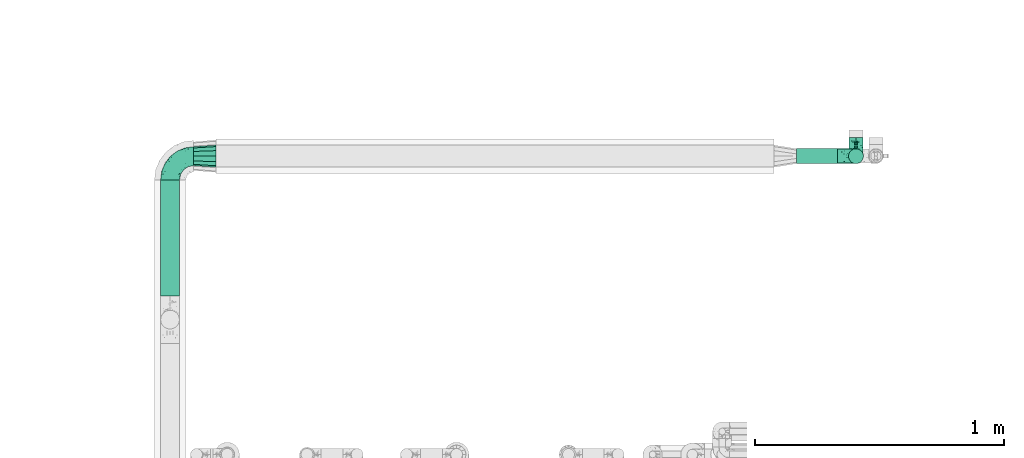
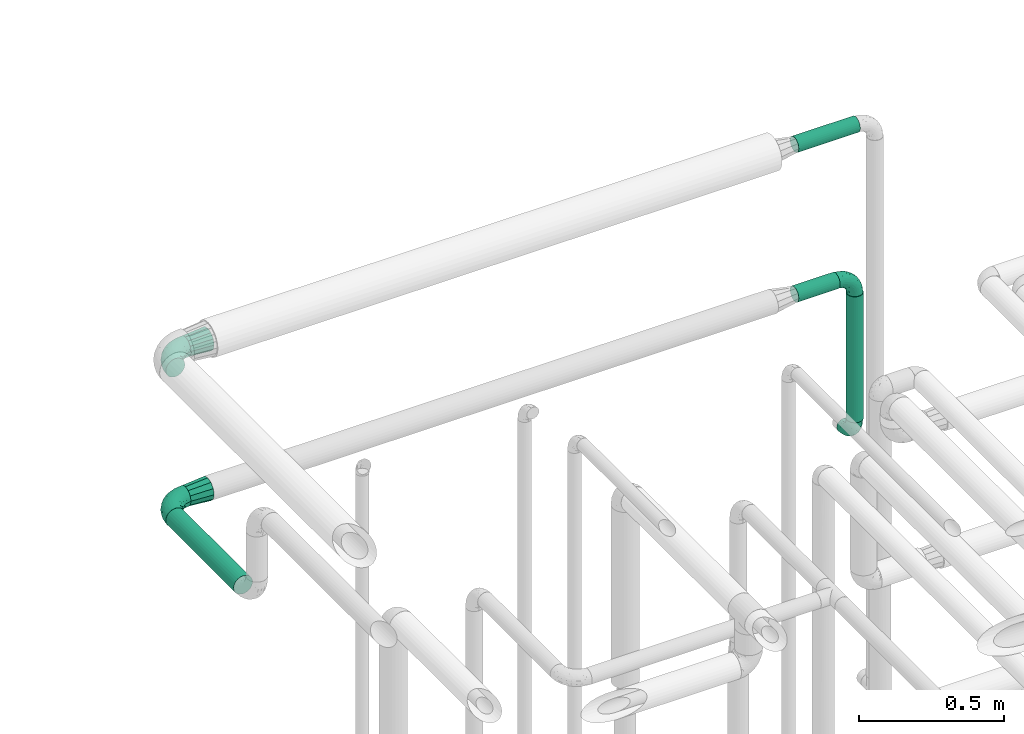
# One storey, part 718 of 827: 6 flow fittings, 4 flow segments.
"""IFC2X3 building model written with IfcOpenShell, lengths in millimetres."""

from ifc_helpers import new_model, entity, si_unit, converted_unit, derived_unit, direction, frame, origin, origin_2d_with_axis, place, context, subcontext, project, spatial, circle, extrude, faceted_brep, source, transform, mapped, material, type_object, type_shapes, element, save


model = new_model("IFC2X3")

# Units and contexts
model_context = context("Model", 3, precision=0.01, world=origin(), true_north=direction((6.12303176911189e-17, 1.0)))
body_context = subcontext(model_context, "Body", "Model", "MODEL_VIEW")
ifc_project = project(units=[si_unit("LENGTHUNIT", "METRE", prefix="MILLI"), si_unit("AREAUNIT", "SQUARE_METRE"), si_unit("VOLUMEUNIT", "CUBIC_METRE"), converted_unit("PLANEANGLEUNIT", "DEGREE", entity("IfcRatioMeasure", 0.0174532925199433), si_unit("PLANEANGLEUNIT", "RADIAN"), dimensions=[0, 0, 0, 0, 0, 0, 0]), si_unit("MASSUNIT", "GRAM", prefix="KILO"), derived_unit("MASSDENSITYUNIT", [(si_unit("MASSUNIT", "GRAM", prefix="KILO"), 1), (si_unit("LENGTHUNIT", "METRE"), -3)]), derived_unit("MOMENTOFINERTIAUNIT", [(si_unit("LENGTHUNIT", "METRE"), 4)]), si_unit("TIMEUNIT", "SECOND"), si_unit("FREQUENCYUNIT", "HERTZ"), si_unit("THERMODYNAMICTEMPERATUREUNIT", "DEGREE_CELSIUS"), derived_unit("THERMALTRANSMITTANCEUNIT", [(si_unit("MASSUNIT", "GRAM", prefix="KILO"), 1), (si_unit("THERMODYNAMICTEMPERATUREUNIT", "KELVIN"), -1), (si_unit("TIMEUNIT", "SECOND"), -3)]), derived_unit("VOLUMETRICFLOWRATEUNIT", [(si_unit("LENGTHUNIT", "METRE"), 3), (si_unit("TIMEUNIT", "SECOND"), -1)]), derived_unit("MASSFLOWRATEUNIT", [(si_unit("MASSUNIT", "GRAM", prefix="KILO"), 1), (si_unit("TIMEUNIT", "SECOND"), -1)]), derived_unit("ROTATIONALFREQUENCYUNIT", [(si_unit("TIMEUNIT", "SECOND"), -1)]), si_unit("ELECTRICCURRENTUNIT", "AMPERE"), si_unit("ELECTRICVOLTAGEUNIT", "VOLT"), si_unit("POWERUNIT", "WATT"), si_unit("FORCEUNIT", "NEWTON", prefix="KILO"), si_unit("ILLUMINANCEUNIT", "LUX"), si_unit("LUMINOUSFLUXUNIT", "LUMEN"), si_unit("LUMINOUSINTENSITYUNIT", "CANDELA"), derived_unit("USERDEFINED", [(si_unit("MASSUNIT", "GRAM", prefix="KILO"), -1), (si_unit("LENGTHUNIT", "METRE"), -2), (si_unit("TIMEUNIT", "SECOND"), 3), (si_unit("LUMINOUSFLUXUNIT", "LUMEN"), 1)]), derived_unit("LINEARVELOCITYUNIT", [(si_unit("LENGTHUNIT", "METRE"), 1), (si_unit("TIMEUNIT", "SECOND"), -1)]), si_unit("PRESSUREUNIT", "PASCAL"), derived_unit("USERDEFINED", [(si_unit("LENGTHUNIT", "METRE"), -2), (si_unit("MASSUNIT", "GRAM", prefix="KILO"), 1), (si_unit("TIMEUNIT", "SECOND"), -2)]), derived_unit("LINEARFORCEUNIT", [(si_unit("MASSUNIT", "GRAM", prefix="KILO"), 1), (si_unit("LENGTHUNIT", "METRE"), 1), (si_unit("TIMEUNIT", "SECOND"), -2), (si_unit("LENGTHUNIT", "METRE"), -1)]), derived_unit("PLANARFORCEUNIT", [(si_unit("MASSUNIT", "GRAM", prefix="KILO"), 1), (si_unit("LENGTHUNIT", "METRE"), 1), (si_unit("TIMEUNIT", "SECOND"), -2), (si_unit("LENGTHUNIT", "METRE"), -2)])], contexts=[model_context])

# Site, building, storey
site_placement = place(None, origin())
site = spatial("IfcSite", under=ifc_project, at=site_placement, CompositionType="ELEMENT")
building_placement = place(site_placement, origin())
building = spatial("IfcBuilding", under=site, at=building_placement, CompositionType="ELEMENT")
storey_placement = place(building_placement, frame((0.0, 0.0, 28200.0)))
storey = spatial("IfcBuildingStorey", under=building, at=storey_placement, Name="08", CompositionType="ELEMENT", Elevation=28200.0)

# Flow segments
pipe_segment_type = type_object("IfcPipeSegmentType", PredefinedType="NOTDEFINED")
flow_segment_1_placement = place(storey_placement, frame((51928.76, 18137.38, 2280.65)))
element("IfcFlowSegment", 1, at=flow_segment_1_placement, inside=storey, type_object=pipe_segment_type, context=body_context, shape_type="SweptSolid", body=[
    extrude(circle(Radius=37.75, at=origin_2d_with_axis()), frame((39.35, 0.0, 39.35), z_axis=(0.0, 1.0, 0.0), x_axis=(1.0, 0.0, 0.0)), (0.0, 0.0, 1.0), 467.828436561252),
])
flow_segment_2_placement = place(storey_placement, frame((54488.07, 18668.61, 2918.4)))
element("IfcFlowSegment", 2, at=flow_segment_2_placement, inside=storey, type_object=pipe_segment_type, context=body_context, shape_type="SweptSolid", body=[
    extrude(circle(Radius=30.0, at=origin_2d_with_axis()), frame((0.0, 31.6, 31.6), z_axis=(1.0, 0.0, 0.0), x_axis=(0.0, -1.0, 0.0)), (0.0, 0.0, 1.0), 245.000000000014),
])
flow_segment_3_placement = place(storey_placement, frame((54488.07, 18668.61, 2288.4)))
element("IfcFlowSegment", 3, at=flow_segment_3_placement, inside=storey, type_object=pipe_segment_type, context=body_context, shape_type="SweptSolid", body=[
    extrude(circle(Radius=30.0, at=origin_2d_with_axis()), frame((0.0, 31.6, 31.6), z_axis=(1.0, 0.0, 0.0), x_axis=(0.0, -1.0, 0.0)), (0.0, 0.0, 1.0), 165.000000000014),
])
flow_segment_4_placement = place(storey_placement, frame((54696.47, 18668.61, 1714.93)))
element("IfcFlowSegment", 4, at=flow_segment_4_placement, inside=storey, type_object=pipe_segment_type, context=body_context, shape_type="SweptSolid", body=[
    extrude(circle(Radius=30.0, at=origin_2d_with_axis()), frame((31.6, 31.6, 0.0)), (0.0, 0.0, 1.0), 530.074764587964),
])

# Flow fittings
ifc_material = material()
pipe_fitting_type_1 = type_object("IfcPipeFittingType", Name="ADSK_1", PredefinedType="NOTDEFINED", material=ifc_material)
shared_shape_1 = source(origin(), body_context, "Body", "Brep", [
    faceted_brep([(-95.0, 19.02, -32.95), (-95.0, 9.85, -36.75), (-95.0, 0.0, -38.05), (-95.0, -9.85, -36.75), (-95.0, -19.03, -32.95), (-95.0, -26.91, -26.91), (-95.0, -32.95, -19.03), (-95.0, -36.75, -9.85), (-95.0, -38.05, 0.0), (-95.0, -36.75, 9.85), (-95.0, -32.95, 19.02), (-95.0, -26.91, 26.91), (-95.0, -19.03, 32.95), (-95.0, -9.85, 36.75), (-95.0, 0.0, 38.05), (-95.0, 9.85, 36.75), (-95.0, 19.02, 32.95), (-95.0, 26.91, 26.91), (-95.0, 32.95, 19.02), (-95.0, 36.75, 9.85), (-95.0, 38.05, 0.0), (-95.0, 36.75, -9.85), (-95.0, 32.95, -19.03), (-95.0, 26.91, -26.91), (0.0, 95.0, -38.05), (-9.85, 95.0, -36.75), (-19.02, 95.0, -32.95), (-26.91, 95.0, -26.91), (-32.95, 95.0, -19.03), (-36.75, 95.0, -9.85), (-38.05, 95.0, 0.0), (-36.75, 95.0, 9.85), (-32.95, 95.0, 19.02), (-26.91, 95.0, 26.91), (-19.02, 95.0, 32.95), (-9.85, 95.0, 36.75), (0.0, 95.0, 38.05), (9.85, 95.0, 36.75), (19.03, 95.0, 32.95), (26.91, 95.0, 26.91), (32.95, 95.0, 19.02), (36.75, 95.0, 9.85), (38.05, 95.0, 0.0), (36.75, 95.0, -9.85), (32.95, 95.0, -19.03), (26.91, 95.0, -26.91), (19.03, 95.0, -32.95), (9.85, 95.0, -36.75), (-7.99, -4.96, 6.3), (-0.92, 0.92, 0.0), (4.62, 8.1, 8.01), (-76.19, -35.57, 0.0), (-64.32, -32.32, 12.43), (20.51, 62.45, 28.68), (-60.56, -33.52, 0.0), (-70.4, -13.47, 34.42), (-39.61, -5.88, 32.32), (-49.6, 2.07, 37.1), (-70.34, -28.81, 21.71), (14.64, 40.81, 26.5), (5.88, 39.61, 32.32), (3.59, 20.77, 25.31), (-40.45, 68.06, 16.75), (-62.45, -20.51, 28.68), (-44.52, -26.87, 0.0), (-28.47, -20.22, 0.0), (-26.43, -17.83, 8.75), (-76.1, 39.63, 10.76), (-72.74, 37.58, 18.19), (-60.35, 46.18, 14.61), (-13.4, 13.4, 32.12), (-20.77, -3.59, 25.31), (-14.66, 81.47, 35.56), (-6.22, 71.26, 37.92), (-57.5, 42.48, 22.79), (-15.0, 34.74, 37.7), (-27.1, 12.08, 36.05), (-9.2, 28.81, 35.63), (-79.98, 23.7, 30.95), (-73.68, -4.3, 37.48), (-30.74, 21.67, 37.97), (-62.36, 47.59, 6.79), (-72.71, 32.83, 24.69), (-67.42, 7.02, 37.95), (-32.13, 75.27, 24.51), (-43.46, 51.47, 26.26), (-24.98, 73.15, 31.29), (20.59, 41.28, 19.85), (7.79, 16.09, 15.86), (-73.21, 42.39, 0.0), (-54.73, 54.73, 0.0), (-73.44, 15.79, 35.79), (-5.94, 4.32, 20.43), (28.81, 70.34, 21.71), (32.32, 64.32, 12.43), (-53.59, 26.2, 35.09), (-52.02, 19.31, 37.21), (21.38, 33.53, 10.34), (26.87, 44.52, 0.0), (-48.28, 12.14, 38.05), (4.3, 73.68, 37.48), (-44.08, -25.52, 12.79), (-41.28, -20.59, 19.85), (35.57, 76.19, 0.0), (-47.26, 54.3, 20.18), (-47.4, 61.99, 8.58), (-42.39, 73.21, 0.0), (-39.67, 78.86, 7.21), (-45.69, 36.84, 33.11), (-32.83, 50.13, 33.35), (13.47, 70.4, 34.42), (-18.25, 63.73, 36.07), (-40.63, -13.75, 27.22), (-16.63, 46.37, 37.95), (-53.47, 38.79, 28.59), (-26.07, 48.54, 36.15), (-34.51, 34.51, 36.86), (-2.07, 49.6, 37.1), (-22.79, -10.49, 19.23), (-61.73, 28.67, 31.87), (9.65, 14.7, 0.0), (20.22, 28.47, 0.0), (33.52, 60.56, 0.0), (-11.42, -5.44, 13.25), (-14.7, -9.65, 0.0), (-81.47, 14.66, -35.56), (-62.45, -20.51, -28.68), (-71.26, 6.22, -37.92), (-75.27, 32.13, -24.51), (-73.15, 24.98, -31.29), (13.47, 70.4, -34.42), (5.88, 39.61, -32.32), (-2.07, 49.6, -37.1), (-78.86, 39.67, -7.21), (-70.4, -13.47, -34.42), (-39.61, -5.88, -32.32), (-61.99, 47.4, -8.58), (32.32, 64.32, -12.43), (28.81, 70.34, -21.71), (-63.73, 18.25, -36.07), (-50.13, 32.83, -33.35), (4.3, 73.68, -37.48), (-7.02, 67.42, -37.95), (-39.63, 76.1, -10.76), (-46.18, 60.35, -14.61), (-47.59, 62.36, -6.79), (-64.32, -32.32, -12.43), (-26.2, 53.59, -35.09), (-15.79, 73.44, -35.79), (-19.31, 52.02, -37.21), (-37.58, 72.74, -18.19), (-70.34, -28.81, -21.71), (-42.48, 57.5, -22.79), (-38.79, 53.47, -28.59), (-51.47, 43.46, -26.26), (-32.83, 72.71, -24.69), (-46.37, 16.63, -37.95), (-73.68, -4.3, -37.48), (-41.28, -20.59, -19.85), (-44.08, -25.52, -12.79), (13.75, 40.63, -27.22), (20.51, 62.45, -28.68), (-68.06, 40.45, -16.75), (-54.3, 47.26, -20.18), (-12.14, 48.28, -38.05), (-21.67, 30.74, -37.97), (-36.84, 45.69, -33.11), (-11.42, -5.44, -13.25), (7.79, 16.09, -15.86), (4.62, 8.1, -8.01), (-23.7, 79.98, -30.95), (-26.43, -17.83, -8.75), (-7.99, -4.96, -6.3), (-40.81, -14.64, -26.5), (-20.77, -3.59, -25.31), (-34.74, 15.0, -37.7), (-12.08, 27.1, -36.05), (-28.81, 9.2, -35.63), (-22.79, -10.49, -19.23), (21.38, 33.53, -10.34), (20.59, 41.28, -19.85), (-48.54, 26.07, -36.15), (-49.6, 2.07, -37.1), (-13.4, 13.4, -32.12), (3.59, 20.77, -25.31), (-28.67, 61.73, -31.87), (-34.51, 34.51, -36.86), (-5.94, 4.32, -20.43)], [[[0, 1, 2, 3, 4, 5, 6, 7, 8, 9, 10, 11, 12, 13, 14, 15, 16, 17, 18, 19, 20, 21, 22, 23]], [[24, 25, 26, 27, 28, 29, 30, 31, 32, 33, 34, 35, 36, 37, 38, 39, 40, 41, 42, 43, 44, 45, 46, 47]], [[48, 49, 50]], [[51, 52, 9]], [[53, 39, 38]], [[9, 52, 10]], [[54, 52, 51]], [[55, 56, 57]], [[11, 10, 58]], [[59, 60, 61]], [[32, 31, 62]], [[63, 12, 11]], [[63, 55, 12]], [[64, 65, 66]], [[67, 68, 69]], [[70, 56, 71]], [[35, 72, 73]], [[69, 68, 74]], [[75, 76, 77]], [[16, 78, 17]], [[13, 79, 14]], [[76, 75, 80]], [[67, 69, 81]], [[18, 17, 82]], [[14, 79, 83]], [[20, 19, 67]], [[84, 85, 86]], [[87, 61, 88]], [[89, 81, 90]], [[18, 82, 68]], [[15, 91, 16]], [[14, 83, 15]], [[71, 92, 61]], [[17, 78, 82]], [[93, 87, 94]], [[95, 91, 96]], [[97, 98, 94]], [[86, 72, 34]], [[96, 99, 80]], [[37, 36, 100]], [[40, 39, 93]], [[40, 94, 41]], [[64, 66, 101]], [[93, 94, 40]], [[58, 102, 63]], [[94, 103, 41]], [[94, 87, 97]], [[104, 69, 74]], [[34, 33, 86]], [[105, 69, 104]], [[52, 58, 10]], [[106, 107, 30]], [[108, 109, 85]], [[105, 106, 90]], [[53, 110, 60]], [[86, 111, 72]], [[86, 109, 111]], [[33, 84, 86]], [[12, 55, 13]], [[112, 56, 63]], [[110, 38, 37]], [[34, 72, 35]], [[36, 35, 73]], [[111, 113, 73]], [[105, 107, 106]], [[110, 53, 38]], [[74, 114, 85]], [[91, 15, 83]], [[105, 90, 81]], [[107, 62, 31]], [[33, 32, 84]], [[115, 109, 116]], [[111, 115, 113]], [[100, 73, 117]], [[56, 55, 63]], [[79, 55, 57]], [[102, 118, 112]], [[56, 70, 76]], [[100, 110, 37]], [[117, 77, 60]], [[117, 60, 110]], [[60, 70, 61]], [[58, 52, 101]], [[63, 11, 58]], [[39, 53, 93]], [[87, 93, 53]], [[96, 91, 83]], [[78, 91, 119]], [[32, 62, 84]], [[84, 62, 104]], [[86, 85, 109]], [[85, 114, 108]], [[80, 113, 116]], [[117, 73, 113]], [[80, 116, 96]], [[80, 57, 76]], [[71, 112, 118]], [[61, 87, 59]], [[62, 107, 105]], [[97, 120, 121]], [[70, 71, 61]], [[71, 118, 92]], [[73, 100, 36]], [[110, 100, 117]], [[55, 79, 13]], [[83, 79, 57]], [[96, 83, 99]], [[116, 108, 95]], [[50, 97, 88]], [[97, 87, 88]], [[50, 49, 120]], [[122, 94, 98]], [[89, 20, 67]], [[105, 81, 69]], [[89, 67, 81]], [[68, 19, 18]], [[68, 67, 19]], [[74, 68, 82]], [[114, 82, 119]], [[74, 85, 104]], [[82, 114, 74]], [[114, 119, 108]], [[95, 108, 119]], [[116, 109, 108]], [[123, 48, 50]], [[97, 50, 120]], [[123, 50, 88]], [[91, 95, 119]], [[116, 95, 96]], [[84, 104, 85]], [[104, 62, 105]], [[83, 57, 99]], [[57, 80, 99]], [[66, 48, 123]], [[66, 124, 48]], [[118, 66, 123]], [[124, 66, 65]], [[66, 118, 101]], [[54, 64, 52]], [[124, 49, 48]], [[30, 107, 31]], [[91, 78, 16]], [[82, 78, 119]], [[56, 76, 57]], [[77, 76, 70]], [[60, 77, 70]], [[77, 117, 75]], [[117, 113, 75]], [[113, 80, 75]], [[9, 8, 51]], [[103, 94, 122]], [[103, 42, 41]], [[73, 72, 111]], [[113, 115, 116]], [[111, 109, 115]], [[102, 112, 63]], [[71, 56, 112]], [[118, 102, 101]], [[92, 123, 88]], [[123, 92, 118]], [[61, 92, 88]], [[87, 53, 59]], [[60, 59, 53]], [[97, 121, 98]], [[58, 101, 102]], [[64, 101, 52]], [[125, 1, 0]], [[126, 5, 4]], [[2, 1, 127]], [[1, 125, 127]], [[128, 129, 23]], [[130, 131, 132]], [[89, 133, 20]], [[126, 134, 135]], [[136, 89, 90]], [[137, 138, 44]], [[139, 129, 140]], [[24, 141, 142]], [[143, 144, 145]], [[125, 129, 139]], [[6, 146, 7]], [[147, 148, 149]], [[146, 51, 7]], [[143, 150, 144]], [[146, 6, 151]], [[152, 153, 154]], [[126, 4, 134]], [[0, 23, 129]], [[28, 155, 150]], [[43, 42, 103]], [[54, 146, 64]], [[139, 156, 127]], [[157, 3, 2]], [[151, 158, 159]], [[160, 131, 161]], [[22, 21, 162]], [[136, 144, 163]], [[149, 164, 165]], [[24, 142, 25]], [[166, 140, 154]], [[154, 129, 128]], [[143, 30, 29]], [[167, 168, 169]], [[155, 28, 27]], [[26, 170, 27]], [[171, 167, 172]], [[26, 25, 148]], [[27, 170, 155]], [[173, 135, 174]], [[144, 150, 152]], [[175, 176, 177]], [[24, 47, 141]], [[45, 161, 46]], [[148, 25, 142]], [[176, 175, 165]], [[64, 159, 171]], [[138, 45, 44]], [[130, 46, 161]], [[137, 44, 43]], [[178, 159, 158]], [[137, 103, 122]], [[163, 144, 152]], [[136, 133, 89]], [[103, 137, 43]], [[6, 5, 151]], [[178, 158, 173]], [[134, 4, 3]], [[178, 173, 174]], [[137, 98, 179]], [[145, 90, 106]], [[138, 180, 161]], [[46, 130, 47]], [[136, 90, 145]], [[133, 162, 21]], [[23, 22, 128]], [[139, 140, 181]], [[139, 181, 156]], [[157, 127, 182]], [[157, 134, 3]], [[182, 177, 135]], [[182, 135, 134]], [[135, 183, 174]], [[131, 130, 161]], [[141, 130, 132]], [[160, 180, 184]], [[131, 183, 176]], [[5, 126, 151]], [[158, 151, 126]], [[180, 138, 137]], [[161, 45, 138]], [[149, 148, 142]], [[170, 148, 185]], [[22, 162, 128]], [[128, 162, 163]], [[129, 154, 140]], [[154, 153, 166]], [[165, 156, 186]], [[182, 127, 156]], [[165, 186, 149]], [[165, 132, 176]], [[131, 184, 183]], [[187, 167, 178]], [[184, 168, 187]], [[167, 169, 172]], [[184, 180, 168]], [[174, 183, 184]], [[127, 157, 2]], [[134, 157, 182]], [[130, 141, 47]], [[142, 141, 132]], [[149, 142, 164]], [[186, 166, 147]], [[180, 179, 168]], [[169, 179, 120]], [[137, 179, 180]], [[179, 121, 120]], [[106, 30, 143]], [[136, 145, 144]], [[106, 143, 145]], [[150, 29, 28]], [[150, 143, 29]], [[152, 150, 155]], [[153, 155, 185]], [[152, 154, 163]], [[155, 153, 152]], [[153, 185, 166]], [[147, 166, 185]], [[186, 140, 166]], [[169, 120, 49]], [[169, 49, 172]], [[179, 169, 168]], [[148, 147, 185]], [[186, 147, 149]], [[128, 163, 154]], [[163, 162, 136]], [[142, 132, 164]], [[132, 165, 164]], [[171, 124, 65]], [[124, 171, 172]], [[64, 146, 159]], [[171, 159, 178]], [[171, 65, 64]], [[172, 49, 124]], [[162, 133, 136]], [[20, 133, 21]], [[148, 170, 26]], [[155, 170, 185]], [[131, 176, 132]], [[177, 176, 183]], [[135, 177, 183]], [[177, 182, 175]], [[182, 156, 175]], [[156, 165, 175]], [[51, 146, 54]], [[51, 8, 7]], [[129, 125, 0]], [[127, 125, 139]], [[140, 186, 181]], [[156, 181, 186]], [[158, 126, 173]], [[135, 173, 126]], [[187, 178, 174]], [[171, 178, 167]], [[184, 187, 174]], [[167, 187, 168]], [[180, 160, 161]], [[184, 131, 160]], [[98, 137, 122]], [[98, 121, 179]], [[151, 159, 146]]]),
])
type_shapes(pipe_fitting_type_1, [shared_shape_1])
for number, where, z_axis, x_axis, name in (
    (5, (51968.37, 18700.2, 2950.0), (0.0, 0.0, 1.0), (-1.0, 0.0, 0.0), "ADSK_1"),
    (6, (51968.1, 18700.2, 2320.0), (0.0, 0.0, 1.0), (-1.0, 0.0, 0.0), "ADSK_1"),
):
    element("IfcFlowFitting", number, at=place(storey_placement, frame(where, z_axis=z_axis, x_axis=x_axis)), inside=storey, type_object=pipe_fitting_type_1, material=ifc_material, Name=name, ObjectType="ADSK_1", context=body_context, shape_type="MappedRepresentation", body=[
        mapped(shared_shape_1, transform((0.0, 0.0, 0.0), scale=1.0)),
    ])
pipe_fitting_type_2 = type_object("IfcPipeFittingType", Name="ADSK_2", PredefinedType="NOTDEFINED", material=ifc_material)
shared_shape_2 = source(origin(), body_context, "Body", "Brep", [
    faceted_brep([(-75.0, 0.0, -28.5), (-75.0, -7.38, -27.53), (-75.0, -14.25, -24.68), (-75.0, -20.15, -20.15), (-75.0, -24.68, -14.25), (-75.0, -27.53, -7.38), (-75.0, -28.5, 0.0), (-75.0, -27.53, 7.38), (-75.0, -24.68, 14.25), (-75.0, -20.15, 20.15), (-75.0, -14.25, 24.68), (-75.0, -7.38, 27.53), (-75.0, 0.0, 28.5), (-75.0, 7.38, 27.53), (-75.0, 14.25, 24.68), (-75.0, 20.15, 20.15), (-75.0, 24.68, 14.25), (-75.0, 27.53, 7.38), (-75.0, 28.5, 0.0), (-75.0, 27.53, -7.38), (-75.0, 24.68, -14.25), (-75.0, 20.15, -20.15), (-75.0, 14.25, -24.68), (-75.0, 7.38, -27.53), (-7.38, 75.0, -27.53), (-14.25, 75.0, -24.68), (-20.15, 75.0, -20.15), (-24.68, 75.0, -14.25), (-27.53, 75.0, -7.38), (-28.5, 75.0, 0.0), (-27.53, 75.0, 7.38), (-24.68, 75.0, 14.25), (-20.15, 75.0, 20.15), (-14.25, 75.0, 24.68), (-7.38, 75.0, 27.53), (0.0, 75.0, 28.5), (7.38, 75.0, 27.53), (14.25, 75.0, 24.68), (20.15, 75.0, 20.15), (24.68, 75.0, 14.25), (27.53, 75.0, 7.38), (28.5, 75.0, 0.0), (27.53, 75.0, -7.38), (24.68, 75.0, -14.25), (20.15, 75.0, -20.15), (14.25, 75.0, -24.68), (7.38, 75.0, -27.53), (0.0, 75.0, -28.5), (-58.34, -3.09, 28.08), (-53.36, 5.47, 28.42), (-60.98, -26.28, 0.0), (-50.38, -23.9, 9.36), (-2.72, 2.72, 0.0), (3.49, 8.33, 5.39), (-8.47, -3.6, 5.43), (-43.02, -23.43, 0.0), (9.86, 31.5, 19.95), (3.58, 31.64, 24.39), (0.78, 15.8, 19.09), (-55.53, -21.42, 16.31), (-41.02, 15.05, 27.84), (-38.36, 9.63, 28.5), (-24.63, 17.21, 28.45), (14.9, 48.57, 21.5), (-48.57, -14.9, 21.5), (-55.48, -9.89, 25.8), (-22.48, -12.99, 7.59), (-28.59, -16.08, 0.0), (-14.16, -8.73, 0.0), (-38.26, 22.79, 26.22), (-58.0, 11.98, 26.79), (-31.64, -3.58, 24.39), (-39.5, 2.0, 27.82), (-30.52, 53.58, 12.47), (-11.07, 64.24, 26.62), (-4.85, 56.28, 28.4), (-62.79, 17.89, 23.17), (-57.59, 24.67, 18.42), (-50.35, 32.08, 12.72), (-63.79, 27.28, 11.71), (-11.91, 27.95, 28.26), (-21.91, 10.04, 27.08), (-7.9, 23.21, 26.78), (8.73, 14.16, 0.0), (-61.42, 30.11, 4.72), (-44.0, 30.05, 19.91), (-2.0, 39.5, 27.82), (9.89, 55.48, 25.8), (-11.33, 11.33, 24.21), (-17.5, -1.61, 19.5), (13.94, 30.82, 14.87), (19.0, 37.09, 10.84), (21.42, 55.53, 16.31), (3.09, 58.34, 28.08), (-15.17, -4.71, 14.28), (-39.06, -21.55, 5.21), (-35.82, -18.71, 10.31), (23.9, 50.38, 9.36), (-30.11, 61.42, 4.72), (-38.06, 40.7, 14.41), (-33.21, 40.38, 19.56), (26.28, 60.98, 0.0), (-30.82, -13.94, 14.87), (-18.89, 57.68, 23.4), (-24.2, 59.35, 18.31), (-41.53, 41.53, 6.86), (-34.73, 51.75, 0.0), (-51.75, 34.73, 0.0), (-25.37, 39.36, 24.88), (-36.07, 30.61, 23.61), (-32.31, -9.26, 20.83), (-14.02, 50.19, 26.99), (-13.14, 36.54, 28.42), (16.08, 28.59, 0.0), (12.99, 22.48, 7.59), (20.38, 36.25, 5.56), (23.43, 43.02, 0.0), (-48.14, 22.05, 23.83), (-20.29, 38.18, 27.03), (-27.1, 27.1, 27.56), (6.41, 16.13, 12.8), (-4.24, 6.02, 15.65), (-3.26, 3.26, 10.59), (-64.24, 11.07, -26.62), (-48.57, -14.9, -21.5), (-56.28, 4.85, -28.4), (-59.35, 24.2, -18.31), (-57.68, 18.89, -23.4), (9.89, 55.48, -25.8), (3.58, 31.64, -24.39), (-2.0, 39.5, -27.82), (-61.42, 30.11, -4.72), (-30.11, 61.42, -4.72), (-41.53, 41.53, -6.86), (23.9, 50.38, -9.36), (21.42, 55.53, -16.31), (-50.19, 14.02, -26.99), (-39.36, 25.37, -24.88), (3.09, 58.34, -28.08), (-5.47, 53.36, -28.42), (-11.98, 58.0, -26.79), (-50.38, -23.9, -9.36), (13.94, 30.82, -14.87), (14.9, 48.57, -21.5), (-22.79, 38.26, -26.22), (-15.05, 41.02, -27.84), (-55.53, -21.42, -16.31), (-9.63, 38.36, -28.5), (-17.21, 24.63, -28.45), (-22.48, -12.99, -7.59), (-30.61, 36.07, -23.61), (-58.34, -3.09, -28.08), (-37.09, -19.0, -10.84), (-30.82, -13.94, -14.87), (21.55, 39.06, -5.21), (18.71, 35.82, -10.31), (-23.21, 7.9, -26.78), (-39.5, 2.0, -27.82), (-27.95, 11.91, -28.26), (-36.25, -20.38, -5.56), (-24.67, 57.59, -18.42), (3.6, 8.47, -5.43), (-8.33, -3.49, -5.39), (-17.89, 62.79, -23.17), (-32.46, -10.54, -19.76), (-31.64, -3.58, -24.39), (-17.5, -1.61, -19.5), (-10.04, 21.91, -27.08), (-32.08, 50.35, -12.72), (-27.28, 63.79, -11.71), (-30.05, 44.0, -19.91), (-40.38, 33.21, -19.56), (-55.48, -9.89, -25.8), (-53.58, 30.52, -12.47), (12.99, 22.48, -7.59), (9.13, 31.36, -20.52), (-15.17, -4.71, -14.28), (-4.24, 6.02, -15.65), (-3.26, 3.26, -10.59), (-40.7, 38.06, -14.41), (-36.54, 13.14, -28.42), (-22.05, 48.14, -23.83), (-38.18, 20.29, -27.03), (-11.33, 11.33, -24.21), (0.78, 15.8, -19.09), (-27.1, 27.1, -27.56), (6.41, 16.13, -12.8)], [[[0, 1, 2, 3, 4, 5, 6, 7, 8, 9, 10, 11, 12, 13, 14, 15, 16, 17, 18, 19, 20, 21, 22, 23]], [[24, 25, 26, 27, 28, 29, 30, 31, 32, 33, 34, 35, 36, 37, 38, 39, 40, 41, 42, 43, 44, 45, 46, 47]], [[12, 48, 49]], [[50, 51, 7]], [[52, 53, 54]], [[7, 51, 8]], [[55, 51, 50]], [[56, 57, 58]], [[9, 8, 59]], [[60, 61, 62]], [[63, 38, 37]], [[64, 10, 9]], [[64, 65, 10]], [[66, 67, 68]], [[69, 70, 60]], [[65, 71, 72]], [[31, 30, 73]], [[13, 70, 14]], [[34, 74, 75]], [[14, 76, 15]], [[11, 48, 12]], [[77, 78, 79]], [[80, 81, 82]], [[15, 77, 16]], [[52, 83, 53]], [[18, 17, 84]], [[79, 17, 16]], [[12, 49, 13]], [[77, 85, 78]], [[82, 86, 80]], [[37, 87, 63]], [[88, 71, 89]], [[90, 91, 92]], [[39, 38, 92]], [[87, 37, 36]], [[35, 93, 36]], [[94, 66, 54]], [[35, 34, 75]], [[95, 96, 51]], [[39, 97, 40]], [[98, 30, 29]], [[92, 97, 39]], [[99, 100, 73]], [[97, 101, 40]], [[59, 102, 64]], [[63, 87, 57]], [[100, 103, 104]], [[105, 106, 107]], [[51, 59, 8]], [[106, 98, 29]], [[69, 108, 109]], [[84, 105, 107]], [[89, 71, 110]], [[104, 103, 32]], [[33, 32, 103]], [[108, 111, 103]], [[111, 112, 75]], [[74, 103, 111]], [[74, 34, 33]], [[18, 84, 107]], [[10, 65, 11]], [[113, 114, 83]], [[115, 116, 97]], [[70, 13, 49]], [[76, 77, 15]], [[117, 109, 85]], [[32, 31, 104]], [[111, 108, 118]], [[111, 118, 112]], [[93, 75, 86]], [[71, 65, 64]], [[48, 65, 72]], [[110, 102, 89]], [[71, 88, 81]], [[93, 87, 36]], [[86, 82, 57]], [[86, 57, 87]], [[57, 88, 58]], [[59, 51, 96]], [[64, 9, 59]], [[38, 63, 92]], [[90, 92, 63]], [[60, 70, 49]], [[76, 70, 117]], [[103, 100, 108]], [[69, 109, 117]], [[62, 112, 119]], [[86, 75, 112]], [[62, 119, 60]], [[62, 72, 81]], [[89, 58, 88]], [[52, 54, 68]], [[31, 73, 104]], [[100, 104, 73]], [[102, 94, 89]], [[120, 58, 121]], [[89, 94, 121]], [[58, 90, 56]], [[75, 93, 35]], [[87, 93, 86]], [[65, 48, 11]], [[49, 48, 72]], [[60, 49, 61]], [[69, 60, 119]], [[99, 105, 78]], [[98, 105, 73]], [[7, 6, 50]], [[101, 97, 116]], [[101, 41, 40]], [[96, 95, 66]], [[96, 66, 102]], [[91, 114, 115]], [[115, 114, 113]], [[114, 90, 120]], [[79, 84, 17]], [[105, 84, 78]], [[105, 98, 106]], [[73, 30, 98]], [[70, 76, 14]], [[77, 76, 117]], [[49, 72, 61]], [[72, 62, 61]], [[108, 69, 119]], [[70, 69, 117]], [[108, 100, 109]], [[85, 109, 100]], [[85, 100, 99]], [[117, 85, 77]], [[71, 81, 72]], [[82, 81, 88]], [[57, 82, 88]], [[86, 112, 80]], [[112, 62, 80]], [[81, 80, 62]], [[77, 79, 16]], [[84, 79, 78]], [[103, 74, 33]], [[75, 74, 111]], [[105, 99, 73]], [[85, 99, 78]], [[108, 119, 118]], [[112, 118, 119]], [[122, 54, 53]], [[83, 114, 53]], [[120, 53, 114]], [[94, 54, 122]], [[66, 68, 54]], [[71, 64, 110]], [[102, 110, 64]], [[66, 94, 102]], [[121, 94, 122]], [[120, 121, 122]], [[89, 121, 58]], [[120, 122, 53]], [[58, 120, 90]], [[90, 63, 56]], [[57, 56, 63]], [[59, 96, 102]], [[51, 55, 95]], [[55, 67, 95]], [[66, 95, 67]], [[116, 115, 113]], [[91, 115, 97]], [[92, 91, 97]], [[114, 91, 90]], [[123, 23, 22]], [[124, 3, 2]], [[0, 23, 125]], [[23, 123, 125]], [[126, 127, 21]], [[128, 129, 130]], [[107, 131, 18]], [[29, 132, 106]], [[133, 107, 106]], [[134, 135, 43]], [[136, 127, 137]], [[47, 138, 139]], [[140, 24, 139]], [[123, 127, 136]], [[4, 141, 5]], [[135, 142, 143]], [[141, 50, 5]], [[144, 140, 145]], [[141, 4, 146]], [[145, 147, 148]], [[149, 68, 67]], [[22, 21, 127]], [[144, 137, 150]], [[42, 41, 101]], [[151, 1, 0]], [[152, 146, 153]], [[154, 155, 134]], [[156, 157, 158]], [[132, 133, 106]], [[159, 55, 141]], [[29, 28, 132]], [[47, 139, 24]], [[26, 160, 27]], [[52, 161, 83]], [[68, 162, 52]], [[26, 25, 163]], [[140, 25, 24]], [[164, 165, 166]], [[47, 46, 138]], [[158, 167, 156]], [[160, 168, 169]], [[168, 160, 170]], [[171, 127, 126]], [[45, 143, 128]], [[172, 124, 2]], [[131, 19, 18]], [[20, 19, 173]], [[113, 83, 174]], [[44, 43, 135]], [[143, 45, 44]], [[134, 42, 101]], [[175, 129, 143]], [[134, 101, 116]], [[172, 2, 1]], [[124, 172, 165]], [[42, 134, 43]], [[45, 128, 46]], [[176, 177, 178]], [[179, 171, 173]], [[169, 28, 27]], [[4, 3, 146]], [[136, 180, 125]], [[163, 160, 26]], [[181, 150, 170]], [[21, 20, 126]], [[136, 137, 182]], [[136, 182, 180]], [[151, 125, 157]], [[151, 172, 1]], [[157, 156, 165]], [[157, 165, 172]], [[165, 183, 166]], [[129, 128, 143]], [[138, 128, 130]], [[175, 142, 184]], [[129, 183, 167]], [[3, 124, 146]], [[146, 124, 164]], [[135, 134, 155]], [[143, 44, 135]], [[145, 140, 139]], [[163, 140, 181]], [[127, 171, 137]], [[144, 150, 181]], [[148, 180, 185]], [[157, 125, 180]], [[148, 185, 145]], [[148, 130, 167]], [[52, 162, 161]], [[153, 164, 166]], [[20, 173, 126]], [[171, 126, 173]], [[184, 166, 183]], [[176, 153, 166]], [[129, 184, 183]], [[177, 186, 178]], [[125, 151, 0]], [[172, 151, 157]], [[128, 138, 46]], [[139, 138, 130]], [[145, 139, 147]], [[144, 145, 185]], [[179, 133, 168]], [[131, 133, 173]], [[50, 141, 55]], [[50, 6, 5]], [[152, 149, 159]], [[159, 149, 67]], [[149, 153, 176]], [[186, 174, 161]], [[155, 154, 174]], [[155, 174, 142]], [[133, 131, 107]], [[173, 19, 131]], [[169, 132, 28]], [[133, 132, 168]], [[140, 163, 25]], [[160, 163, 181]], [[139, 130, 147]], [[130, 148, 147]], [[137, 144, 185]], [[140, 144, 181]], [[137, 171, 150]], [[170, 150, 171]], [[170, 171, 179]], [[181, 170, 160]], [[129, 167, 130]], [[156, 167, 183]], [[165, 156, 183]], [[157, 180, 158]], [[180, 148, 158]], [[167, 158, 148]], [[160, 169, 27]], [[132, 169, 168]], [[127, 123, 22]], [[125, 123, 136]], [[133, 179, 173]], [[170, 179, 168]], [[137, 185, 182]], [[180, 182, 185]], [[149, 176, 162]], [[149, 162, 68]], [[162, 178, 161]], [[186, 161, 178]], [[174, 83, 161]], [[146, 164, 153]], [[165, 164, 124]], [[177, 166, 184]], [[176, 178, 162]], [[166, 177, 176]], [[186, 184, 142]], [[184, 186, 177]], [[174, 186, 142]], [[142, 175, 143]], [[184, 129, 175]], [[55, 159, 67]], [[152, 159, 141]], [[146, 152, 141]], [[149, 152, 153]], [[135, 155, 142]], [[134, 116, 154]], [[116, 113, 154]], [[174, 154, 113]]]),
])
type_shapes(pipe_fitting_type_2, [shared_shape_2])
for number, where, z_axis, x_axis, name in (
    (7, (54728.07, 18700.2, 2320.0), (0.0, 1.0, 0.0), (1.0, 0.0, 0.0), "ADSK_2"),
    (8, (54728.07, 18700.2, 1639.93), (1.0, 0.0, 0.0), (0.0, 0.0, -1.0), "ADSK_2"),
):
    element("IfcFlowFitting", number, at=place(storey_placement, frame(where, z_axis=z_axis, x_axis=x_axis)), inside=storey, type_object=pipe_fitting_type_2, material=ifc_material, Name=name, ObjectType="ADSK_2", context=body_context, shape_type="MappedRepresentation", body=[
        mapped(shared_shape_2, transform((0.0, 0.0, 0.0), scale=1.0)),
    ])
pipe_fitting_type_3 = type_object("IfcPipeFittingType", Name="ADSK_1", PredefinedType="NOTDEFINED", material=ifc_material)
shared_shape_3 = source(origin(), body_context, "Body", "Brep", [
    faceted_brep([(89.0, -44.45, 0.0), (89.0, -41.96, -9.31), (89.0, -38.49, -22.22), (89.0, -30.36, -30.36), (89.0, -22.23, -38.49), (89.0, -11.11, -41.47), (89.0, 0.0, -44.45), (89.0, 11.11, -41.47), (89.0, 22.22, -38.49), (89.0, 30.36, -30.36), (89.0, 38.49, -22.22), (89.0, 41.96, -9.31), (89.0, 44.45, 0.0), (89.0, 41.96, 9.31), (89.0, 38.49, 22.23), (89.0, 30.36, 30.36), (89.0, 22.22, 38.49), (89.0, 11.11, 41.47), (89.0, 0.0, 44.45), (89.0, -11.11, 41.47), (89.0, -22.23, 38.49), (89.0, -30.36, 30.36), (89.0, -38.49, 22.23), (89.0, -41.96, 9.31), (0.0, 38.05, 0.0), (0.0, 35.5, -9.51), (0.0, 32.95, -19.02), (0.0, 25.99, -25.99), (0.0, 19.02, -32.95), (0.0, 9.51, -35.5), (0.0, 0.0, -38.05), (0.0, -9.51, -35.5), (0.0, -19.03, -32.95), (0.0, -25.99, -25.99), (0.0, -32.95, -19.02), (0.0, -35.5, -9.51), (0.0, -38.05, 0.0), (0.0, -35.5, 9.51), (0.0, -32.95, 19.03), (0.0, -25.99, 25.99), (0.0, -19.03, 32.95), (0.0, -9.51, 35.5), (0.0, 0.0, 38.05), (0.0, 9.51, 35.5), (0.0, 19.03, 32.95), (0.0, 25.99, 25.99), (0.0, 32.95, 19.03), (0.0, 35.5, 9.51)], [[[0, 1, 2, 3, 4, 5, 6, 7, 8, 9, 10, 11, 12, 13, 14, 15, 16, 17, 18, 19, 20, 21, 22, 23]], [[24, 25, 26, 27, 28, 29, 30, 31, 32, 33, 34, 35, 36, 37, 38, 39, 40, 41, 42, 43, 44, 45, 46, 47]], [[2, 1, 0, 36, 35, 34]], [[28, 8, 7, 6, 30, 29]], [[32, 4, 3, 2, 34, 33]], [[5, 4, 32, 31, 30, 6]], [[10, 26, 25, 24, 12, 11]], [[9, 8, 28, 27, 26, 10]], [[14, 13, 12, 24, 47, 46]], [[40, 20, 19, 18, 42, 41]], [[44, 16, 15, 14, 46, 45]], [[17, 16, 44, 43, 42, 18]], [[22, 38, 37, 36, 0, 23]], [[21, 20, 40, 39, 38, 22]]]),
])
type_shapes(pipe_fitting_type_3, [shared_shape_3])
for number, where, name in (
    (9, (52063.37, 18700.2, 2950.0), "ADSK_1"),
    (10, (52063.1, 18700.2, 2320.0), "ADSK_1"),
):
    element("IfcFlowFitting", number, at=place(storey_placement, frame(where)), inside=storey, type_object=pipe_fitting_type_3, material=ifc_material, Name=name, ObjectType="ADSK_1", context=body_context, shape_type="MappedRepresentation", body=[
        mapped(shared_shape_3, transform((0.0, 0.0, 0.0), scale=1.0)),
    ])

save(model, "model.ifc")
